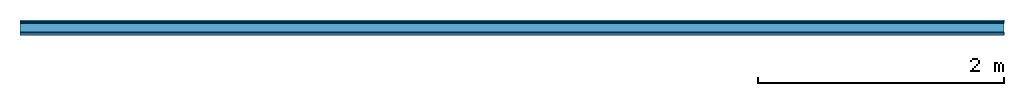
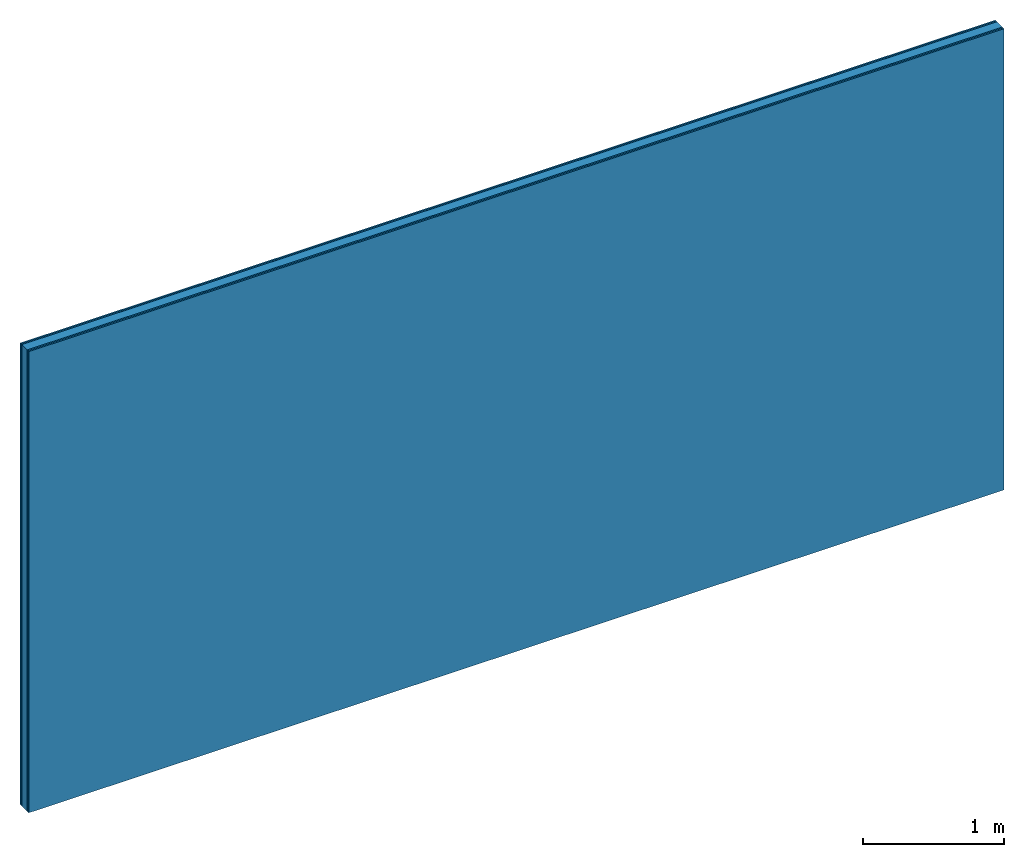
# One storey: 4 plates, 1 member, 1 element without a shape of its own.
"""IFC4 building model written with IfcOpenShell, lengths in metres."""

from ifc_helpers import new_model, si_unit, derived_unit, direction, frame, frame_2d, origin, origin_with_axes, place, context, project, spatial, rectangle, extrude, material, layer, layer_set, type_object, element, aggregate, save


model = new_model("IFC4")

# Units and contexts
plan_context = context("Plan", 3, precision=1e-05, world=origin(), true_north=direction((0.0, 1.0)))
model_context = context("Model", 3, precision=1e-05, world=origin(), true_north=direction((0.0, 1.0)))
ifc_project = project(units=[si_unit("LENGTHUNIT", "METRE"), derived_unit("SOUNDPRESSUREUNIT", [(si_unit("PRESSUREUNIT", "PASCAL", prefix="MICRO"), 0)]), si_unit("ENERGYUNIT", "JOULE", prefix="MEGA"), si_unit("MASSUNIT", "GRAM", prefix="KILO"), derived_unit("THERMALTRANSMITTANCEUNIT", [(si_unit("POWERUNIT", "WATT"), 1), (si_unit("AREAUNIT", "SQUARE_METRE"), -1), (si_unit("THERMODYNAMICTEMPERATUREUNIT", "KELVIN"), -1)]), derived_unit("AREADENSITYUNIT", [(si_unit("MASSUNIT", "GRAM", prefix="KILO"), 1), (si_unit("AREAUNIT", "SQUARE_METRE"), -1)]), derived_unit("USERDEFINED", [(si_unit("ENERGYUNIT", "JOULE", prefix="MEGA"), 1), (si_unit("AREAUNIT", "SQUARE_METRE"), -1)])], contexts=[plan_context, model_context])

# Site, building, storey
site = spatial("IfcSite", under=ifc_project)
building_placement = place(None, origin())
building = spatial("IfcBuilding", under=site, at=building_placement)
storey_placement = place(building_placement, origin())
storey = spatial("IfcBuildingStorey", under=building, at=storey_placement)

# Wall, member, plates
ifc_material_1 = material(Name="joints", Category="04.017")
ifc_layer_1 = layer(ifc_material_1, 0.0, Name="Surface")
ifc_material_2 = material(Name="Rigidur H", Category="03.007")
ifc_layer_2 = layer(ifc_material_2, 0.0125, Name="2nd layer")
ifc_layer_3 = layer(ifc_material_2, 0.0125, Name="1st layer")
ifc_material_3 = material(Name="of the art")
ifc_layer_4 = layer(ifc_material_3, 0.0, Name="Bond")
ifc_layer_5 = layer(None, 0.075, Name="Support")
ifc_layer_6 = layer(ifc_material_3, 0.0, Name="Bond")
ifc_layer_7 = layer(ifc_material_2, 0.0125, Name="1st layer")
ifc_layer_8 = layer(ifc_material_2, 0.0125, Name="2nd layer")
ifc_layer_9 = layer(ifc_material_1, 0.0, Name="Surface")
ifc_layer_set = layer_set([ifc_layer_1, ifc_layer_2, ifc_layer_3, ifc_layer_4, ifc_layer_5, ifc_layer_6, ifc_layer_7, ifc_layer_8, ifc_layer_9])
wall_type = type_object("IfcWallType", Name="C0471", PredefinedType="NOTDEFINED", material=ifc_layer_set)
wall_placement = place(None, frame((0.0, 0.0, 0.0), z_axis=(0.0, -1.0, 0.0), x_axis=(1.0, 0.0, 0.0)))
wall = element("IfcWall", 1, at=wall_placement, inside=storey, type_object=wall_type, material=ifc_layer_set, Name="Wall #1")
ifc_material_4 = material(Name="OSB")
member_placement = place(wall_placement, origin())
member = element("IfcMember", 2, at=member_placement, material=ifc_material_4, Name="Support", context=plan_context, shape_type="SweptSolid", body=[
    extrude(rectangle(XDim=1.0, YDim=0.075, at=frame_2d((0.5, 0.0375), x_axis=(1.0, 0.0))), frame((0.0, 4.0, 0.025), z_axis=(0.0, -1.0, 0.0), x_axis=(1.0, 0.0, 0.0)), (0.0, 0.0, 1.0), 4.0),
    extrude(rectangle(XDim=1.0, YDim=0.075, at=frame_2d((0.5, 0.0375), x_axis=(1.0, 0.0))), frame((1.0, 4.0, 0.025), z_axis=(0.0, -1.0, 0.0), x_axis=(1.0, 0.0, 0.0)), (0.0, 0.0, 1.0), 4.0),
    extrude(rectangle(XDim=1.0, YDim=0.075, at=frame_2d((0.5, 0.0375), x_axis=(1.0, 0.0))), frame((2.0, 4.0, 0.025), z_axis=(0.0, -1.0, 0.0), x_axis=(1.0, 0.0, 0.0)), (0.0, 0.0, 1.0), 4.0),
    extrude(rectangle(XDim=1.0, YDim=0.075, at=frame_2d((0.5, 0.0375), x_axis=(1.0, 0.0))), frame((3.0, 4.0, 0.025), z_axis=(0.0, -1.0, 0.0), x_axis=(1.0, 0.0, 0.0)), (0.0, 0.0, 1.0), 4.0),
    extrude(rectangle(XDim=1.0, YDim=0.075, at=frame_2d((0.5, 0.0375), x_axis=(1.0, 0.0))), frame((4.0, 4.0, 0.025), z_axis=(0.0, -1.0, 0.0), x_axis=(1.0, 0.0, 0.0)), (0.0, 0.0, 1.0), 4.0),
    extrude(rectangle(XDim=1.0, YDim=0.075, at=frame_2d((0.5, 0.0375), x_axis=(1.0, 0.0))), frame((5.0, 4.0, 0.025), z_axis=(0.0, -1.0, 0.0), x_axis=(1.0, 0.0, 0.0)), (0.0, 0.0, 1.0), 4.0),
    extrude(rectangle(XDim=1.0, YDim=0.075, at=frame_2d((0.5, 0.0375), x_axis=(1.0, 0.0))), frame((6.0, 4.0, 0.025), z_axis=(0.0, -1.0, 0.0), x_axis=(1.0, 0.0, 0.0)), (0.0, 0.0, 1.0), 4.0),
    extrude(rectangle(XDim=1.0, YDim=0.075, at=frame_2d((0.5, 0.0375), x_axis=(1.0, 0.0))), frame((7.0, 4.0, 0.025), z_axis=(0.0, -1.0, 0.0), x_axis=(1.0, 0.0, 0.0)), (0.0, 0.0, 1.0), 4.0),
])
plate_1_placement = place(wall_placement, origin())
plate_1 = element("IfcPlate", 3, at=plate_1_placement, material=ifc_material_2, Name="2nd layer", context=plan_context, shape_type="SweptSolid", body=[
    extrude(rectangle(XDim=8.0, YDim=4.0, at=frame_2d((4.0, 2.0), x_axis=(1.0, 0.0))), origin_with_axes(), (0.0, 0.0, 1.0), 0.0125),
])
plate_2_placement = place(wall_placement, origin())
plate_2 = element("IfcPlate", 4, at=plate_2_placement, material=ifc_material_2, Name="1st layer", context=plan_context, shape_type="SweptSolid", body=[
    extrude(rectangle(XDim=8.0, YDim=4.0, at=frame_2d((4.0, 2.0), x_axis=(1.0, 0.0))), frame((0.0, 0.0, 0.0125), z_axis=(0.0, 0.0, 1.0), x_axis=(1.0, 0.0, 0.0)), (0.0, 0.0, 1.0), 0.0125),
])
plate_3_placement = place(wall_placement, origin())
plate_3 = element("IfcPlate", 5, at=plate_3_placement, material=ifc_material_2, Name="1st layer", context=plan_context, shape_type="SweptSolid", body=[
    extrude(rectangle(XDim=8.0, YDim=4.0, at=frame_2d((4.0, 2.0), x_axis=(1.0, 0.0))), frame((0.0, 0.0, 0.1), z_axis=(0.0, 0.0, 1.0), x_axis=(1.0, 0.0, 0.0)), (0.0, 0.0, 1.0), 0.0125),
])
plate_4_placement = place(wall_placement, origin())
plate_4 = element("IfcPlate", 6, at=plate_4_placement, material=ifc_material_2, Name="2nd layer", context=plan_context, shape_type="SweptSolid", body=[
    extrude(rectangle(XDim=8.0, YDim=4.0, at=frame_2d((4.0, 2.0), x_axis=(1.0, 0.0))), frame((0.0, 0.0, 0.1125), z_axis=(0.0, 0.0, 1.0), x_axis=(1.0, 0.0, 0.0)), (0.0, 0.0, 1.0), 0.0125),
])
aggregate(wall, [plate_1, plate_2, member, plate_3, plate_4])

save(model, "model.ifc")
